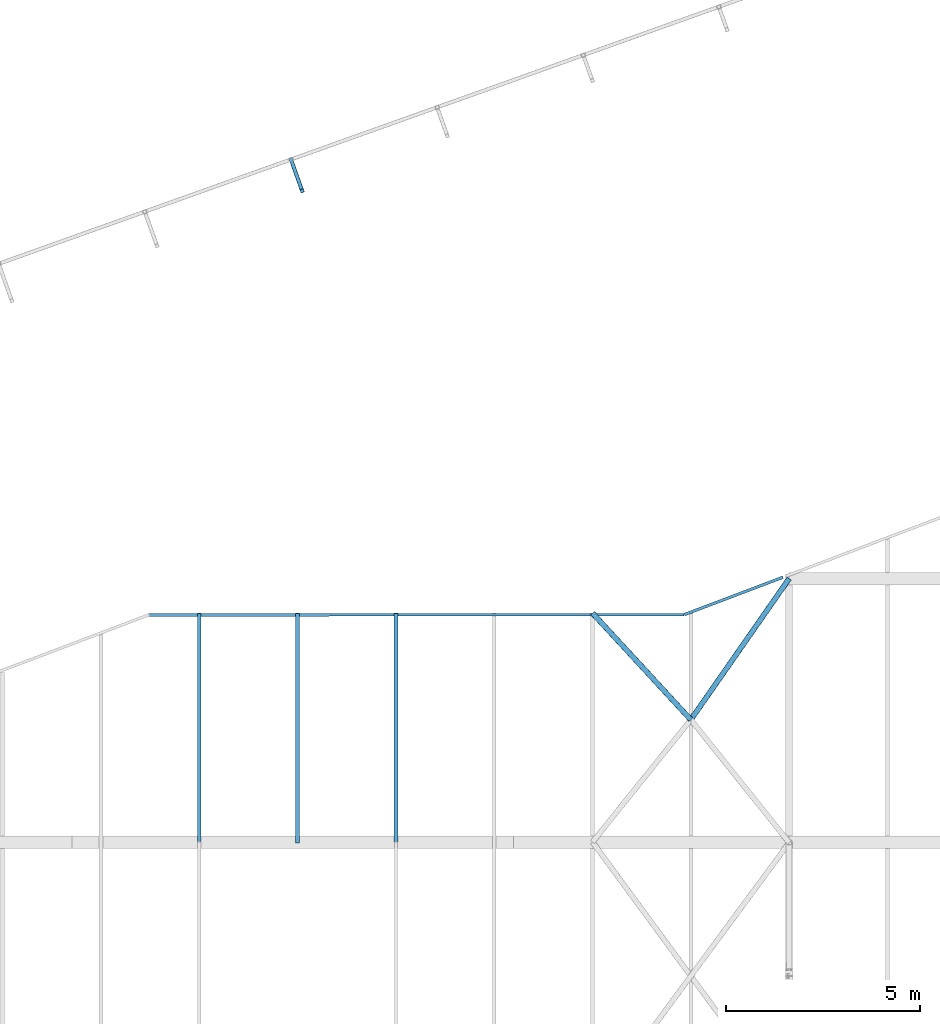
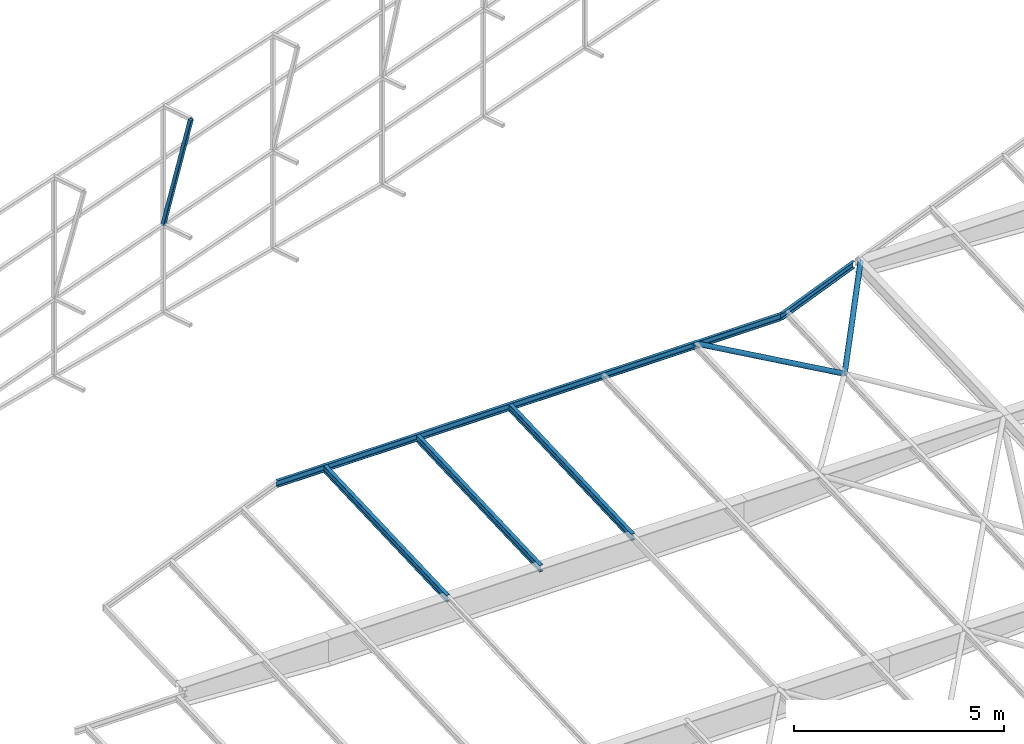
# One storey, part 131 of 215: 7 beams, 1 member, 8 elements without a shape of their own.
"""IFC2X3 building model written with IfcOpenShell, lengths in millimetres."""

import ifcopenshell
import ifcopenshell.guid

model = None  # the IFC model being written
_history = None  # IfcOwnerHistory: only IFC2X3 demands one
_inside = {}  # id of a spatial element -> (the spatial element, [elements in it])
_under = {}  # id of a project, library or spatial element -> (it, [spatial elements below it])
_declared = {}  # id of a project -> (the project, [libraries it declares])
_typed = {}  # id of a type object -> (the type object, [elements of that type])
_made_of = {}  # id of a material, layer set ... -> (it, [elements and type objects made of it])


def new_model(schema):
    """Start an empty IFC model of exactly this schema.

    Asked for "IFC4X3", IfcOpenShell would pick the latest addendum, in which some entities
    have other attributes; the version numbers below select the first issue.
    IFC2X3 requires an IfcOwnerHistory on every rooted entity: one is made here for all.
    """
    global model, _history
    if schema == "IFC4X3":
        model = ifcopenshell.file(schema_version=(4, 3, 0, 0))
    else:
        model = ifcopenshell.file(schema=schema)
    _inside.clear()
    _under.clear()
    _declared.clear()
    _typed.clear()
    _made_of.clear()
    _history = None
    if model.schema == "IFC2X3":
        org = make("IfcOrganization", Name="unknown")
        user = make(
            "IfcPersonAndOrganization",
            ThePerson=make("IfcPerson", FamilyName="unknown"),
            TheOrganization=org,
        )
        app = make(
            "IfcApplication",
            ApplicationDeveloper=org,
            Version="unknown",
            ApplicationFullName="unknown",
            ApplicationIdentifier="unknown",
        )
        _history = make(
            "IfcOwnerHistory",
            OwningUser=user,
            OwningApplication=app,
            ChangeAction="ADDED",
            CreationDate=0,
        )
    return model


def make(cls, **values):
    """One entity of the class cls with the attributes given. An attribute that is None is left unset."""
    return model.create_entity(
        cls, **{name: value for name, value in values.items() if value is not None}
    )


def rooted(cls, **values):
    """An entity with a GlobalId (a new one), such as an element, a storey or a relation."""
    return make(cls, GlobalId=ifcopenshell.guid.new(), OwnerHistory=_history, **values)


def si_unit(unit_type, name, prefix=None):
    """IfcSIUnit, for example si_unit("LENGTHUNIT", "METRE", prefix="MILLI")."""
    return make("IfcSIUnit", UnitType=unit_type, Prefix=prefix, Name=name)


def assignment(units):
    """IfcUnitAssignment: the units of a project."""
    return None if units is None else make("IfcUnitAssignment", Units=units)


def point(xyz):
    """IfcCartesianPoint."""
    return None if xyz is None else make("IfcCartesianPoint", Coordinates=xyz)


def direction(xyz):
    """IfcDirection."""
    return None if xyz is None else make("IfcDirection", DirectionRatios=xyz)


def frame(location, z_axis=None, x_axis=None):
    """IfcAxis2Placement3D, a coordinate frame: its origin and axes. An axis left out is left unset."""
    return make(
        "IfcAxis2Placement3D",
        Location=point(location),
        Axis=direction(z_axis),
        RefDirection=direction(x_axis),
    )


def frame_2d(location, x_axis=None):
    """IfcAxis2Placement2D, a coordinate frame in the plane: its origin and x axis."""
    return make(
        "IfcAxis2Placement2D", Location=point(location), RefDirection=direction(x_axis)
    )


def origin_with_axes():
    """The frame at (0, 0, 0) with the z axis (0, 0, 1) and the x axis (1, 0, 0) written out."""
    return frame((0.0, 0.0, 0.0), z_axis=(0.0, 0.0, 1.0), x_axis=(1.0, 0.0, 0.0))


def origin_2d_with_axis():
    """The frame at (0, 0) in the plane with the x axis (1, 0) written out."""
    return frame_2d((0.0, 0.0), x_axis=(1.0, 0.0))


def place(relative_to, where):
    """IfcLocalPlacement: puts the frame where relative to a parent placement (None: the world)."""
    return make(
        "IfcLocalPlacement", PlacementRelTo=relative_to, RelativePlacement=where
    )


def context(
    kind, dimensions, precision=None, world=None, true_north=None, identifier=None
):
    """IfcGeometricRepresentationContext, for example the 3D "Model" context."""
    return make(
        "IfcGeometricRepresentationContext",
        ContextIdentifier=identifier,
        ContextType=kind,
        CoordinateSpaceDimension=dimensions,
        Precision=precision,
        WorldCoordinateSystem=world,
        TrueNorth=true_north,
    )


def subcontext(parent, identifier, kind, view, scale=None):
    """IfcGeometricRepresentationSubContext, for example "Body" below "Model"."""
    return make(
        "IfcGeometricRepresentationSubContext",
        ContextIdentifier=identifier,
        ContextType=kind,
        ParentContext=parent,
        TargetScale=scale,
        TargetView=view,
    )


def project(units=None, contexts=None):
    """IfcProject with its units and contexts."""
    return rooted(
        "IfcProject",
        Name="project",
        RepresentationContexts=contexts,
        UnitsInContext=assignment(units),
    )


def spatial(cls, under=None, at=None, **own):
    """A site, building, storey or space (cls), placed at a placement, below another one or the project."""
    s = rooted(cls, ObjectPlacement=at, **own)
    if under is not None:
        _under.setdefault(under.id(), (under, []))[1].append(s)
    return s


def profile(cls, at=None, kind="AREA", **sizes):
    """A parametric profile (cls). Its sizes go by their IFC names, for example OverallWidth=200.0."""
    return make(cls, ProfileType=kind, Position=at, **sizes)


def hollow_rectangle(**sizes):
    """IfcRectangleHollowProfileDef."""
    return profile("IfcRectangleHollowProfileDef", **sizes)


def hollow_circle(**sizes):
    """IfcCircleHollowProfileDef."""
    return profile("IfcCircleHollowProfileDef", **sizes)


def i_section(**sizes):
    """IfcIShapeProfileDef."""
    return profile("IfcIShapeProfileDef", **sizes)


def u_section(**sizes):
    """IfcUShapeProfileDef."""
    return profile("IfcUShapeProfileDef", **sizes)


def extrude(swept, where, along, depth):
    """IfcExtrudedAreaSolid: the profile swept, set in the frame where, extruded along a direction by depth."""
    return make(
        "IfcExtrudedAreaSolid",
        SweptArea=swept,
        Position=where,
        ExtrudedDirection=direction(along),
        Depth=depth,
    )


def shape(context_of_items, identifier, shape_type, items):
    """IfcShapeRepresentation: the items that make up one representation, for example the "Body"."""
    return make(
        "IfcShapeRepresentation",
        ContextOfItems=context_of_items,
        RepresentationIdentifier=identifier,
        RepresentationType=shape_type,
        Items=items,
    )


def material(Name=None, Category=None):
    """IfcMaterial."""
    return make("IfcMaterial", Name=Name, Category=Category)


def made_of(thing, what):
    """Note that an element or type object is made of a material, layer set ...; save() writes the relation."""
    if what is not None:
        _made_of.setdefault(what.id(), (what, []))[1].append(thing)
    return thing


def type_object(cls, material=None, **own):
    """A type object (cls), such as IfcWallType, which elements share."""
    return made_of(rooted(cls, **own), material)


def element(
    cls,
    number,
    at=None,
    inside=None,
    cuts=None,
    type_object=None,
    material=None,
    context=None,
    identifier="Body",
    shape_type=None,
    held_by="IfcProductDefinitionShape",
    body=None,
    shapes=None,
    **own,
):
    """One element of the class cls, such as IfcWall. Its Tag is "e" and its number.

    at: its placement. inside: the storey or other place that contains it. cuts: it is an
    opening in that element (IfcRelVoidsElement). A single representation is given by context,
    identifier, shape_type and body (its items); several are given by shapes. held_by: the class
    of the entity that holds the representations. save() writes the other relations.
    """
    e = rooted(cls, Tag="e%d" % number, ObjectPlacement=at, **own)
    if body is not None:
        shapes = [shape(context, identifier, shape_type, body)]
    if shapes is not None:
        e.Representation = make(held_by, Representations=shapes)
    if inside is not None:
        _inside.setdefault(inside.id(), (inside, []))[1].append(e)
    if cuts is not None:
        rooted(
            "IfcRelVoidsElement", RelatingBuildingElement=cuts, RelatedOpeningElement=e
        )
    if type_object is not None:
        _typed.setdefault(type_object.id(), (type_object, []))[1].append(e)
    return made_of(e, material)


def aggregate(whole, parts):
    """IfcRelAggregates: a whole, such as a stair, and the parts it consists of."""
    return rooted("IfcRelAggregates", RelatingObject=whole, RelatedObjects=parts)


def save(model, path):
    """Write the relations noted so far, then the file.

    IfcRelAggregates (storeys below a building ...), IfcRelContainedInSpatialStructure (elements
    in a storey), IfcRelDefinesByType, IfcRelAssociatesMaterial and IfcRelDeclares: one each for
    every whole, place, type object, material and project.
    """
    for whole, parts in _under.values():
        aggregate(whole, parts)
    for where, things in _inside.values():
        rooted(
            "IfcRelContainedInSpatialStructure",
            RelatedElements=things,
            RelatingStructure=where,
        )
    for kind, things in _typed.values():
        rooted("IfcRelDefinesByType", RelatedObjects=things, RelatingType=kind)
    for what, things in _made_of.values():
        rooted("IfcRelAssociatesMaterial", RelatedObjects=things, RelatingMaterial=what)
    for by, libraries in _declared.values():
        rooted("IfcRelDeclares", RelatingContext=by, RelatedDefinitions=libraries)
    model.write(path)


model = new_model("IFC2X3")

# Units and contexts
model_context = context("Model", 3, precision=1e-05, world=origin_with_axes())
body_context = subcontext(model_context, "Body", "Model", "MODEL_VIEW")
ifc_project = project(units=[si_unit("LENGTHUNIT", "METRE", prefix="MILLI"), si_unit("AREAUNIT", "SQUARE_METRE"), si_unit("VOLUMEUNIT", "CUBIC_METRE"), si_unit("MASSUNIT", "GRAM", prefix="KILO"), si_unit("TIMEUNIT", "SECOND"), si_unit("PLANEANGLEUNIT", "RADIAN"), si_unit("SOLIDANGLEUNIT", "STERADIAN"), si_unit("THERMODYNAMICTEMPERATUREUNIT", "DEGREE_CELSIUS"), si_unit("LUMINOUSINTENSITYUNIT", "LUMEN")], contexts=[model_context])

# Site, building, storey
site_placement = place(None, origin_with_axes())
site = spatial("IfcSite", under=ifc_project, at=site_placement, CompositionType="ELEMENT")
building_placement = place(site_placement, origin_with_axes())
building = spatial("IfcBuilding", under=site, at=building_placement, Name="Undefined", CompositionType="ELEMENT")
storey_placement = place(building_placement, origin_with_axes())
storey = spatial("IfcBuildingStorey", under=building, at=storey_placement, Name="Undefined", CompositionType="ELEMENT", Elevation=0.0)

# Assembly, member
assembly_1_placement = place(storey_placement, origin_with_axes())
assembly_1 = element("IfcElementAssembly", 1, at=assembly_1_placement, inside=storey, Name="Steel Assembly", AssemblyPlace="NOTDEFINED", PredefinedType="RIGID_FRAME")
ifc_material_1 = material(Name="STEEL/S275JR")
member_type = type_object("IfcMemberType", PredefinedType="NOTDEFINED")
member_placement = place(assembly_1_placement, frame((116943.821101526, 79409.6379886376, 6706.70982133654), z_axis=(0.941802170974673, 0.33616762299096, 0.0), x_axis=(-0.0813305580263413, 0.227854468073791, -0.970292575314237)))
member = element("IfcMember", 2, at=member_placement, type_object=member_type, material=ifc_material_1, Name="LISSE", context=body_context, shape_type="SweptSolid", body=[
    extrude(hollow_rectangle(XDim=100.0, YDim=100.0, WallThickness=4.0, InnerFilletRadius=4.0, OuterFilletRadius=8.0, at=origin_2d_with_axis()), frame((3552.23980775789, -1.46505096889559e-11, 3.33865388269902e-14), z_axis=(-1.0, 0.0, 0.0), x_axis=(-6.93889390390723e-18, -1.0, -3.46944695195361e-18)), (0.0, 0.0, 1.0), 3552.2),
])
aggregate(assembly_1, [member])

# Assembly, beam
assembly_2_placement = place(storey_placement, origin_with_axes())
assembly_2 = element("IfcElementAssembly", 3, at=assembly_2_placement, inside=storey, Name="Steel Assembly", AssemblyPlace="NOTDEFINED", PredefinedType="RIGID_FRAME")
beam_type_1 = type_object("IfcBeamType", Name="UPN200", PredefinedType="NOTDEFINED")
beam_1_placement = place(assembly_2_placement, frame((112975.703239164, 68455.1220506805, 4170.63406379345), z_axis=(2.00000067686167e-09, -1.44859999985136e-05, 0.999999999895078), x_axis=(0.999999986057504, 0.00016698800000942, 0.0)))
beam_1 = element("IfcBeam", 4, at=beam_1_placement, type_object=beam_type_1, material=ifc_material_1, ObjectType="UPN200", context=body_context, shape_type="SweptSolid", body=[
    extrude(u_section(Depth=200.0, FlangeWidth=75.0, WebThickness=8.5, FlangeThickness=11.5, FilletRadius=11.5, EdgeRadius=6.0, FlangeSlope=0.0798299857122373, at=origin_2d_with_axis()), frame((13826.6952002306, 3.74773324359624e-16, -5.71858710265539e-21), z_axis=(-1.0, 0.0, 0.0), x_axis=(-6.93889390390723e-18, -1.0, -3.46944695195361e-18)), (0.0, 0.0, 1.0), 13826.7),
])
aggregate(assembly_2, [beam_1])

assembly_3_placement = place(storey_placement, origin_with_axes())
assembly_3 = element("IfcElementAssembly", 5, at=assembly_3_placement, inside=storey, Name="Steel Assembly", AssemblyPlace="NOTDEFINED", PredefinedType="RIGID_FRAME")
beam_2_placement = place(assembly_3_placement, frame((129364.820333806, 69425.9202453131, 4210.36360959799), z_axis=(0.0136442699978212, 0.00517077199917034, -0.999893542840016), x_axis=(-0.935003402907376, -0.354338444964897, -0.0145911949985548)))
beam_2 = element("IfcBeam", 6, at=beam_2_placement, type_object=beam_type_1, material=ifc_material_1, Name="POUTRE", ObjectType="UPN200", context=body_context, shape_type="SweptSolid", body=[
    extrude(u_section(Depth=200.0, FlangeWidth=75.0, WebThickness=8.5, FlangeThickness=11.5, FilletRadius=11.5, EdgeRadius=6.0, FlangeSlope=0.0798299857122373, at=origin_2d_with_axis()), frame((2722.07697311038, 7.36700697390488e-12, 4.50025300057794e-13), z_axis=(-1.0, 0.0, 0.0), x_axis=(-6.93889390390723e-18, -1.0, -3.46944695195361e-18)), (0.0, 0.0, 1.0), 2722.1),
])
aggregate(assembly_3, [beam_2])

assembly_4_placement = place(storey_placement, origin_with_axes())
assembly_4 = element("IfcElementAssembly", 7, at=assembly_4_placement, inside=storey, Name="Steel Assembly", AssemblyPlace="NOTDEFINED", PredefinedType="RIGID_FRAME")
beam_type_2 = type_object("IfcBeamType", Name="IPE200", PredefinedType="NOTDEFINED")
beam_3_placement = place(assembly_4_placement, frame((119365.009192844, 62591.0647314119, 3934.40114185938), z_axis=(0.0, -0.0399624260079826, 0.999201183199638), x_axis=(0.0, 0.999201183199638, 0.0399624260079844)))
beam_3 = element("IfcBeam", 8, at=beam_3_placement, type_object=beam_type_2, material=ifc_material_1, ObjectType="IPE200", context=body_context, shape_type="SweptSolid", body=[
    extrude(i_section(OverallWidth=100.0, OverallDepth=200.0, WebThickness=5.599999905, FlangeThickness=8.5, FilletRadius=12.0, at=origin_2d_with_axis()), frame((5913.38844152037, 0.0, 0.0), z_axis=(-1.0, 0.0, 0.0), x_axis=(-6.93889390390723e-18, -1.0, -3.46944695195361e-18)), (0.0, 0.0, 1.0), 5913.4),
])
aggregate(assembly_4, [beam_3])

assembly_5_placement = place(storey_placement, origin_with_axes())
assembly_5 = element("IfcElementAssembly", 9, at=assembly_5_placement, inside=storey, Name="Steel Assembly", AssemblyPlace="NOTDEFINED", PredefinedType="RIGID_FRAME")
beam_4_placement = place(assembly_5_placement, frame((114285.009685602, 62591.0647311523, 3934.40114161561), z_axis=(0.0, -0.0399624260079826, 0.999201183199638), x_axis=(0.0, 0.999201183199638, 0.0399624260079844)))
beam_4 = element("IfcBeam", 10, at=beam_4_placement, type_object=beam_type_2, material=ifc_material_1, ObjectType="IPE200", context=body_context, shape_type="SweptSolid", body=[
    extrude(i_section(OverallWidth=100.0, OverallDepth=200.0, WebThickness=5.599999905, FlangeThickness=8.5, FilletRadius=12.0, at=origin_2d_with_axis()), frame((5913.38844152037, 0.0, 0.0), z_axis=(-1.0, 0.0, 0.0), x_axis=(-6.93889390390723e-18, -1.0, -3.46944695195361e-18)), (0.0, 0.0, 1.0), 5913.4),
])
aggregate(assembly_5, [beam_4])

assembly_6_placement = place(storey_placement, origin_with_axes())
assembly_6 = element("IfcElementAssembly", 11, at=assembly_6_placement, inside=storey, Name="Steel Assembly", AssemblyPlace="NOTDEFINED", PredefinedType="RIGID_FRAME")
beam_5_placement = place(assembly_6_placement, frame((116825.009439226, 62568.0238611457, 3933.47963655235), z_axis=(0.0, -0.0399624260079826, 0.999201183199638), x_axis=(0.0, 0.999201183199638, 0.0399624260079844)))
beam_5 = element("IfcBeam", 12, at=beam_5_placement, type_object=beam_type_2, material=ifc_material_1, ObjectType="IPE200", context=body_context, shape_type="SweptSolid", body=[
    extrude(i_section(OverallWidth=100.0, OverallDepth=200.0, WebThickness=5.599999905, FlangeThickness=8.5, FilletRadius=12.0, at=origin_2d_with_axis()), frame((5936.44773200056, 0.0, 0.0), z_axis=(-1.0, 0.0, 0.0), x_axis=(-6.93889390390723e-18, -1.0, -3.46944695195361e-18)), (0.0, 0.0, 1.0), 5936.4),
])
aggregate(assembly_6, [beam_5])

assembly_7_placement = place(storey_placement, origin_with_axes())
assembly_7 = element("IfcElementAssembly", 13, at=assembly_7_placement, inside=storey, Name="Steel Assembly", AssemblyPlace="NOTDEFINED", PredefinedType="RIGID_FRAME")
ifc_material_2 = material(Name="STEEL/S235JR")
beam_type_3 = type_object("IfcBeamType", PredefinedType="NOTDEFINED")
beam_6_placement = place(assembly_7_placement, frame((126985.008603489, 65745.3073714668, 4090.72115566328), z_axis=(-2.1980000026525e-06, -0.0399625230126959, 0.999201179317573), x_axis=(0.57130422703551, 0.820082702050973, 0.0328000300020386)))
beam_6 = element("IfcBeam", 14, at=beam_6_placement, type_object=beam_type_3, material=ifc_material_2, context=body_context, shape_type="SweptSolid", body=[
    extrude(hollow_circle(Radius=69.84999845, WallThickness=8.0, at=origin_2d_with_axis()), frame((4445.96700202752, 1.46073489898144e-11, 3.08500933273415e-14), z_axis=(-1.0, 0.0, 0.0), x_axis=(-6.93889390390723e-18, -1.0, -3.46944695195361e-18)), (0.0, 0.0, 1.0), 4446.0),
])
aggregate(assembly_7, [beam_6])

assembly_8_placement = place(storey_placement, origin_with_axes())
assembly_8 = element("IfcElementAssembly", 15, at=assembly_8_placement, inside=storey, Name="Steel Assembly", AssemblyPlace="NOTDEFINED", PredefinedType="RIGID_FRAME")
beam_7_placement = place(assembly_8_placement, frame((126985.008513696, 65745.3072949422, 4090.72115262621), z_axis=(-9.29999994281054e-07, -0.0399614169821636, 0.999201223554051), x_axis=(-0.677780929121582, 0.734676620131788, 0.0293815580052706)))
beam_7 = element("IfcBeam", 16, at=beam_7_placement, type_object=beam_type_3, material=ifc_material_2, context=body_context, shape_type="SweptSolid", body=[
    extrude(hollow_circle(Radius=69.84999845, WallThickness=8.0, at=origin_2d_with_axis()), frame((3747.52319365209, 3.72990081938161e-13, 0.0), z_axis=(-1.0, 0.0, 0.0), x_axis=(-6.93889390390723e-18, -1.0, -3.46944695195361e-18)), (0.0, 0.0, 1.0), 3747.5),
])
aggregate(assembly_8, [beam_7])

save(model, "model.ifc")
